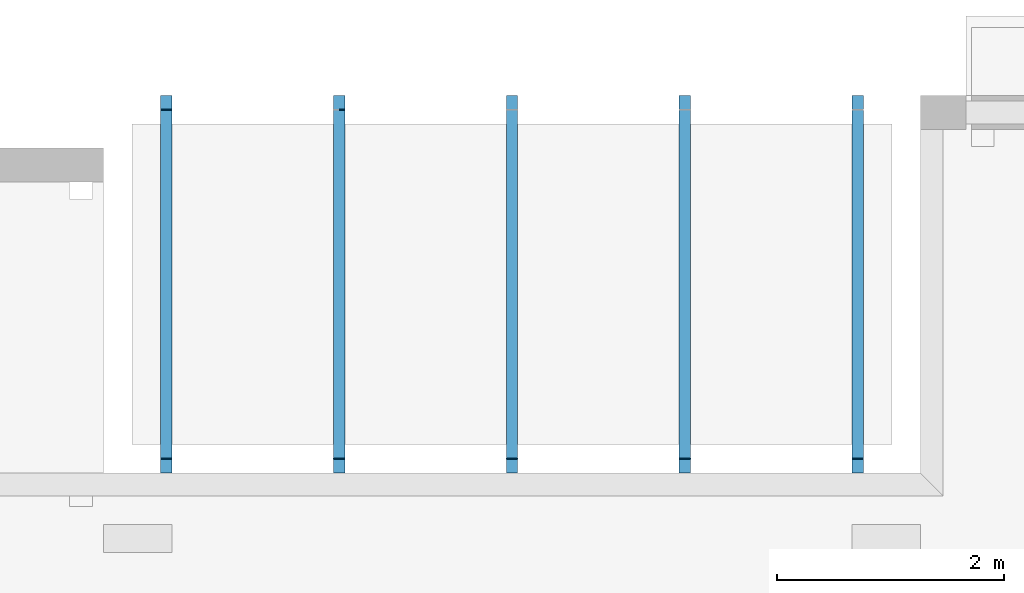
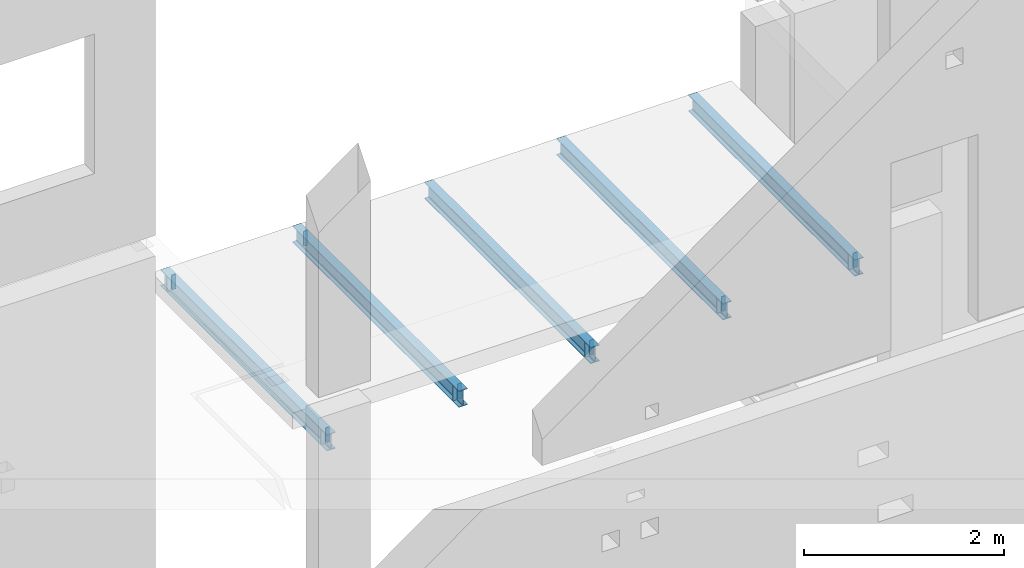
# One storey, part 5 of 7: 18 beams.
"""IFC2X3 building model written with IfcOpenShell, lengths in millimetres."""

from ifc_helpers import new_model, entity, si_unit, converted_unit, derived_unit, money_unit, direction, frame, origin_with_axes, place, context, subcontext, project, spatial, faceted_brep, material, type_object, element, save


model = new_model("IFC2X3")

# Units and contexts
model_context = context("Model", 3, precision=1e-05, world=origin_with_axes(), true_north=direction((0.0, 1.0)))
body_context = subcontext(model_context, "Body", "Model", "MODEL_VIEW", scale=1.0)
ifc_project = project(units=[si_unit("LENGTHUNIT", "METRE", prefix="MILLI"), si_unit("AREAUNIT", "SQUARE_METRE"), si_unit("VOLUMEUNIT", "CUBIC_METRE"), si_unit("ABSORBEDDOSEUNIT", "GRAY"), si_unit("AMOUNTOFSUBSTANCEUNIT", "MOLE"), si_unit("DOSEEQUIVALENTUNIT", "SIEVERT"), si_unit("ELECTRICCAPACITANCEUNIT", "FARAD"), si_unit("ELECTRICCHARGEUNIT", "COULOMB"), si_unit("ELECTRICCONDUCTANCEUNIT", "SIEMENS"), si_unit("ELECTRICCURRENTUNIT", "AMPERE"), si_unit("ELECTRICRESISTANCEUNIT", "OHM"), si_unit("ELECTRICVOLTAGEUNIT", "VOLT"), si_unit("ENERGYUNIT", "JOULE"), si_unit("FORCEUNIT", "NEWTON"), si_unit("FREQUENCYUNIT", "HERTZ"), si_unit("ILLUMINANCEUNIT", "LUX"), si_unit("INDUCTANCEUNIT", "HENRY"), si_unit("LUMINOUSFLUXUNIT", "LUMEN"), si_unit("LUMINOUSINTENSITYUNIT", "CANDELA"), si_unit("MAGNETICFLUXDENSITYUNIT", "TESLA"), si_unit("MAGNETICFLUXUNIT", "WEBER"), si_unit("MASSUNIT", "GRAM"), converted_unit("PLANEANGLEUNIT", "degree", entity("IfcReal", 0.0174532925199433), si_unit("PLANEANGLEUNIT", "RADIAN"), dimensions=[0, 0, 0, 0, 0, 0, 0]), si_unit("POWERUNIT", "WATT"), si_unit("PRESSUREUNIT", "PASCAL"), si_unit("RADIOACTIVITYUNIT", "BECQUEREL"), si_unit("SOLIDANGLEUNIT", "STERADIAN"), si_unit("THERMODYNAMICTEMPERATUREUNIT", "KELVIN"), si_unit("TIMEUNIT", "SECOND"), derived_unit("ACCELERATIONUNIT", [(si_unit("LENGTHUNIT", "METRE", prefix="MILLI"), 1), (si_unit("TIMEUNIT", "SECOND"), -2)]), derived_unit("ANGULARVELOCITYUNIT", [(converted_unit("PLANEANGLEUNIT", "degree", entity("IfcReal", 0.0174532925199433), si_unit("PLANEANGLEUNIT", "RADIAN"), dimensions=[0, 0, 0, 0, 0, 0, 0]), 1), (si_unit("TIMEUNIT", "SECOND"), -1)]), derived_unit("CURVATUREUNIT", [(converted_unit("PLANEANGLEUNIT", "degree", entity("IfcReal", 0.0174532925199433), si_unit("PLANEANGLEUNIT", "RADIAN"), dimensions=[0, 0, 0, 0, 0, 0, 0]), 1), (si_unit("LENGTHUNIT", "METRE", prefix="MILLI"), -1)]), derived_unit("DYNAMICVISCOSITYUNIT", [(si_unit("PRESSUREUNIT", "PASCAL"), 1), (si_unit("TIMEUNIT", "SECOND"), 1)]), derived_unit("HEATFLUXDENSITYUNIT", [(si_unit("POWERUNIT", "WATT"), 1), (si_unit("LENGTHUNIT", "METRE", prefix="MILLI"), -2)]), derived_unit("HEATINGVALUEUNIT", [(si_unit("ENERGYUNIT", "JOULE"), 1), (si_unit("MASSUNIT", "GRAM"), -1)]), derived_unit("INTEGERCOUNTRATEUNIT", [(si_unit("TIMEUNIT", "SECOND"), -1)]), derived_unit("IONCONCENTRATIONUNIT", [(si_unit("MASSUNIT", "GRAM"), 1), (si_unit("VOLUMEUNIT", "CUBIC_METRE"), -1)]), derived_unit("ISOTHERMALMOISTURECAPACITYUNIT", [(si_unit("VOLUMEUNIT", "CUBIC_METRE"), 1), (si_unit("MASSUNIT", "GRAM"), -1)]), derived_unit("KINEMATICVISCOSITYUNIT", [(si_unit("AREAUNIT", "SQUARE_METRE"), 1), (si_unit("TIMEUNIT", "SECOND"), -1)]), derived_unit("LINEARFORCEUNIT", [(si_unit("FORCEUNIT", "NEWTON"), 1), (si_unit("LENGTHUNIT", "METRE", prefix="MILLI"), -1)]), derived_unit("LINEARMOMENTUNIT", [(si_unit("FORCEUNIT", "NEWTON"), 1), (si_unit("LENGTHUNIT", "METRE", prefix="MILLI"), -1)]), derived_unit("LINEARSTIFFNESSUNIT", [(si_unit("FORCEUNIT", "NEWTON"), 1), (si_unit("LENGTHUNIT", "METRE", prefix="MILLI"), -1)]), derived_unit("LINEARVELOCITYUNIT", [(si_unit("LENGTHUNIT", "METRE", prefix="MILLI"), 1), (si_unit("TIMEUNIT", "SECOND"), -1)]), derived_unit("LUMINOUSINTENSITYDISTRIBUTIONUNIT", [(si_unit("LUMINOUSINTENSITYUNIT", "CANDELA"), 1), (si_unit("LUMINOUSFLUXUNIT", "LUMEN"), -1)]), derived_unit("MASSDENSITYUNIT", [(si_unit("MASSUNIT", "GRAM"), 1), (si_unit("VOLUMEUNIT", "CUBIC_METRE"), -1)]), derived_unit("MASSFLOWRATEUNIT", [(si_unit("MASSUNIT", "GRAM"), 1), (si_unit("TIMEUNIT", "SECOND"), -1)]), derived_unit("MASSPERLENGTHUNIT", [(si_unit("MASSUNIT", "GRAM"), 1), (si_unit("LENGTHUNIT", "METRE", prefix="MILLI"), -1)]), derived_unit("MODULUSOFELASTICITYUNIT", [(si_unit("FORCEUNIT", "NEWTON"), 1), (si_unit("AREAUNIT", "SQUARE_METRE"), -1)]), derived_unit("MODULUSOFLINEARSUBGRADEREACTIONUNIT", [(si_unit("FORCEUNIT", "NEWTON"), 1), (si_unit("LENGTHUNIT", "METRE", prefix="MILLI"), -2)]), derived_unit("MODULUSOFROTATIONALSUBGRADEREACTIONUNIT", [(si_unit("FORCEUNIT", "NEWTON"), 1), (si_unit("LENGTHUNIT", "METRE", prefix="MILLI"), 1)]), derived_unit("MODULUSOFSUBGRADEREACTIONUNIT", [(si_unit("FORCEUNIT", "NEWTON"), 1), (si_unit("VOLUMEUNIT", "CUBIC_METRE"), -1)]), derived_unit("MOISTUREDIFFUSIVITYUNIT", [(si_unit("VOLUMEUNIT", "CUBIC_METRE"), 1), (si_unit("TIMEUNIT", "SECOND"), -1)]), derived_unit("MOLECULARWEIGHTUNIT", [(si_unit("MASSUNIT", "GRAM"), 1), (si_unit("AMOUNTOFSUBSTANCEUNIT", "MOLE"), -1)]), derived_unit("PLANARFORCEUNIT", [(si_unit("FORCEUNIT", "NEWTON"), 1), (si_unit("LENGTHUNIT", "METRE", prefix="MILLI"), -2)]), derived_unit("ROTATIONALFREQUENCYUNIT", [(si_unit("TIMEUNIT", "SECOND"), -1)]), derived_unit("ROTATIONALMASSUNIT", [(si_unit("MASSUNIT", "GRAM"), 1), (si_unit("LENGTHUNIT", "METRE", prefix="MILLI"), 2)]), derived_unit("ROTATIONALSTIFFNESSUNIT", [(si_unit("FORCEUNIT", "NEWTON"), 1), (si_unit("LENGTHUNIT", "METRE", prefix="MILLI"), 1), (converted_unit("PLANEANGLEUNIT", "degree", entity("IfcReal", 0.0174532925199433), si_unit("PLANEANGLEUNIT", "RADIAN"), dimensions=[0, 0, 0, 0, 0, 0, 0]), -1)]), derived_unit("SECTIONAREAINTEGRALUNIT", [(si_unit("LENGTHUNIT", "METRE", prefix="MILLI"), 5)]), derived_unit("SECTIONMODULUSUNIT", [(si_unit("LENGTHUNIT", "METRE", prefix="MILLI"), 3)]), derived_unit("SHEARMODULUSUNIT", [(si_unit("FORCEUNIT", "NEWTON"), 1), (si_unit("AREAUNIT", "SQUARE_METRE"), -1)]), derived_unit("SOUNDPOWERUNIT", [(si_unit("ENERGYUNIT", "JOULE"), 1), (si_unit("TIMEUNIT", "SECOND"), -1)]), derived_unit("SPECIFICHEATCAPACITYUNIT", [(si_unit("FORCEUNIT", "NEWTON"), 1), (si_unit("MASSUNIT", "GRAM"), -1), (si_unit("THERMODYNAMICTEMPERATUREUNIT", "KELVIN"), -1)]), derived_unit("TEMPERATUREGRADIENTUNIT", [(si_unit("THERMODYNAMICTEMPERATUREUNIT", "KELVIN"), 1), (si_unit("LENGTHUNIT", "METRE", prefix="MILLI"), -1)]), derived_unit("THERMALADMITTANCEUNIT", [(si_unit("POWERUNIT", "WATT"), 1), (si_unit("AREAUNIT", "SQUARE_METRE"), -1), (si_unit("THERMODYNAMICTEMPERATUREUNIT", "KELVIN"), -1)]), derived_unit("THERMALCONDUCTANCEUNIT", [(si_unit("POWERUNIT", "WATT"), 1), (si_unit("LENGTHUNIT", "METRE", prefix="MILLI"), -1), (si_unit("THERMODYNAMICTEMPERATUREUNIT", "KELVIN"), -1)]), derived_unit("THERMALEXPANSIONCOEFFICIENTUNIT", [(si_unit("THERMODYNAMICTEMPERATUREUNIT", "KELVIN"), -1)]), derived_unit("THERMALRESISTANCEUNIT", [(si_unit("AREAUNIT", "SQUARE_METRE"), 1), (si_unit("POWERUNIT", "WATT"), -1)]), derived_unit("THERMALTRANSMITTANCEUNIT", [(si_unit("POWERUNIT", "WATT"), 1), (si_unit("AREAUNIT", "SQUARE_METRE"), -1), (si_unit("THERMODYNAMICTEMPERATUREUNIT", "KELVIN"), -1)]), derived_unit("TORQUEUNIT", [(si_unit("FORCEUNIT", "NEWTON"), 1), (si_unit("LENGTHUNIT", "METRE", prefix="MILLI"), 1)]), derived_unit("VAPORPERMEABILITYUNIT", [(si_unit("MASSUNIT", "GRAM"), 1), (si_unit("TIMEUNIT", "SECOND"), -1)]), derived_unit("VOLUMETRICFLOWRATEUNIT", [(si_unit("VOLUMEUNIT", "CUBIC_METRE"), 1), (si_unit("TIMEUNIT", "SECOND"), -1)]), derived_unit("WARPINGCONSTANTUNIT", [(si_unit("LENGTHUNIT", "METRE", prefix="MILLI"), 6)]), derived_unit("WARPINGMOMENTUNIT", [(si_unit("FORCEUNIT", "NEWTON"), 1), (si_unit("LENGTHUNIT", "METRE", prefix="MILLI"), 2)]), money_unit("USD")], contexts=[model_context])

# Site, building, storey
site_placement = place(None, origin_with_axes())
site = spatial("IfcSite", under=ifc_project, at=site_placement, CompositionType="ELEMENT")
building_placement = place(site_placement, origin_with_axes())
building = spatial("IfcBuilding", under=site, at=building_placement, Name="1", CompositionType="ELEMENT")
storey_placement = place(building_placement, frame((0.0, 0.0, -4900.0), z_axis=(0.0, 0.0, 1.0), x_axis=(1.0, 0.0, 0.0)))
storey = spatial("IfcBuildingStorey", under=building, at=storey_placement, CompositionType="ELEMENT", Elevation=-4900.0)

# Beams
ifc_material = material()
beam_type = type_object("IfcBeamType", PredefinedType="BEAM")
beam_1_placement = place(storey_placement, frame((0.0, 0.0, 4900.0), z_axis=(0.0, 0.0, 1.0), x_axis=(1.0, 0.0, 0.0)))
element("IfcBeam", 1, at=beam_1_placement, inside=storey, type_object=beam_type, material=ifc_material, context=body_context, shape_type="Brep", body=[
    faceted_brep([(9475.0, 10060.0, -1400.0), (9475.0, 6740.0, -1400.0), (9475.0, 6740.0, -1392.0), (9475.0, 10060.0, -1392.0), (9511.25, 6740.0, -1392.0), (9511.25, 10060.0, -1392.0), (9515.459518, 6740.0, -1391.162675), (9515.459518, 10060.0, -1391.162675), (9519.028175, 6740.0, -1388.778175), (9519.028175, 10060.0, -1388.778175), (9521.412675, 6740.0, -1385.209518), (9521.412675, 10060.0, -1385.209518), (9522.25, 6740.0, -1381.0), (9522.25, 10060.0, -1381.0), (9522.25, 10060.0, -1219.0), (9521.412675, 10060.0, -1214.790482), (9519.028175, 10060.0, -1211.221825), (9515.459518, 10060.0, -1208.837325), (9511.25, 10060.0, -1208.0), (9475.0, 10060.0, -1208.0), (9475.0, 10060.0, -1200.0), (9575.0, 10060.0, -1200.0), (9575.0, 10060.0, -1208.0), (9538.75, 10060.0, -1208.0), (9534.540482, 10060.0, -1208.837325), (9530.971825, 10060.0, -1211.221825), (9528.587325, 10060.0, -1214.790482), (9527.75, 10060.0, -1219.0), (9527.75, 10060.0, -1381.0), (9528.587325, 10060.0, -1385.209518), (9530.971825, 10060.0, -1388.778175), (9534.540482, 10060.0, -1391.162675), (9538.75, 10060.0, -1392.0), (9575.0, 10060.0, -1392.0), (9575.0, 10060.0, -1400.0), (9575.0, 6740.0, -1400.0), (9575.0, 6740.0, -1392.0), (9538.75, 6740.0, -1392.0), (9534.540482, 6740.0, -1391.162675), (9530.971825, 6740.0, -1388.778175), (9528.587325, 6740.0, -1385.209518), (9527.75, 6740.0, -1381.0), (9527.75, 6740.0, -1219.0), (9528.587325, 6740.0, -1214.790482), (9530.971825, 6740.0, -1211.221825), (9534.540482, 6740.0, -1208.837325), (9538.75, 6740.0, -1208.0), (9575.0, 6740.0, -1208.0), (9575.0, 6740.0, -1200.0), (9475.0, 6740.0, -1200.0), (9475.0, 6740.0, -1208.0), (9511.25, 6740.0, -1208.0), (9515.459518, 6740.0, -1208.837325), (9519.028175, 6740.0, -1211.221825), (9521.412675, 6740.0, -1214.790482), (9522.25, 6740.0, -1219.0)], [[[0, 1, 2, 3]], [[3, 2, 4, 5]], [[5, 4, 6, 7]], [[7, 6, 8, 9]], [[9, 8, 10, 11]], [[11, 10, 12, 13]], [[0, 3, 5, 7, 9, 11, 13, 14, 15, 16, 17, 18, 19, 20, 21, 22, 23, 24, 25, 26, 27, 28, 29, 30, 31, 32, 33, 34]], [[35, 36, 37, 38, 39, 40, 41, 42, 43, 44, 45, 46, 47, 48, 49, 50, 51, 52, 53, 54, 55, 12, 10, 8, 6, 4, 2, 1]], [[13, 12, 55, 14]], [[14, 55, 54, 15]], [[15, 54, 53, 16]], [[16, 53, 52, 17]], [[17, 52, 51, 18]], [[18, 51, 50, 19]], [[19, 50, 49, 20]], [[20, 49, 48, 21]], [[21, 48, 47, 22]], [[22, 47, 46, 23]], [[23, 46, 45, 24]], [[24, 45, 44, 25]], [[25, 44, 43, 26]], [[26, 43, 42, 27]], [[27, 42, 41, 28]], [[28, 41, 40, 29]], [[29, 40, 39, 30]], [[30, 39, 38, 31]], [[31, 38, 37, 32]], [[32, 37, 36, 33]], [[33, 36, 35, 34]], [[34, 35, 1, 0]]]),
])
beam_2_placement = place(storey_placement, frame((0.0, 0.0, 4900.0), z_axis=(0.0, 0.0, 1.0), x_axis=(1.0, 0.0, 0.0)))
element("IfcBeam", 2, at=beam_2_placement, inside=storey, type_object=beam_type, material=ifc_material, context=body_context, shape_type="Brep", body=[
    faceted_brep([(9527.0, 6860.0, -1382.0), (9538.0, 6860.0, -1392.0), (9575.0, 6860.0, -1392.0), (9575.0, 6860.0, -1208.0), (9537.0, 6860.0, -1208.0), (9527.0, 6860.0, -1218.0), (9538.0, 6870.0, -1392.0), (9527.0, 6870.0, -1382.0), (9527.0, 6870.0, -1218.0), (9537.0, 6870.0, -1208.0), (9575.0, 6870.0, -1208.0), (9575.0, 6870.0, -1392.0)], [[[0, 1, 2, 3, 4, 5]], [[6, 7, 8, 9, 10, 11]], [[3, 2, 11, 10]], [[6, 11, 2, 1]], [[9, 4, 3, 10]], [[8, 7, 0, 5]], [[7, 6, 1, 0]], [[9, 8, 5, 4]]]),
])
beam_3_placement = place(storey_placement, frame((0.0, 0.0, 4900.0), z_axis=(0.0, 0.0, 1.0), x_axis=(1.0, 0.0, 0.0)))
element("IfcBeam", 3, at=beam_3_placement, inside=storey, type_object=beam_type, material=ifc_material, context=body_context, shape_type="Brep", body=[
    faceted_brep([(9512.0, 6860.0, -1392.0), (9523.0, 6860.0, -1382.0), (9523.0, 6860.0, -1218.0), (9513.0, 6860.0, -1208.0), (9475.0, 6860.0, -1208.0), (9475.0, 6860.0, -1392.0), (9523.0, 6870.0, -1382.0), (9512.0, 6870.0, -1392.0), (9475.0, 6870.0, -1392.0), (9475.0, 6870.0, -1208.0), (9513.0, 6870.0, -1208.0), (9523.0, 6870.0, -1218.0)], [[[0, 1, 2, 3, 4, 5]], [[6, 7, 8, 9, 10, 11]], [[0, 5, 8, 7]], [[3, 10, 9, 4]], [[9, 8, 5, 4]], [[7, 6, 1, 0]], [[6, 11, 2, 1]], [[11, 10, 3, 2]]]),
])
beam_4_placement = place(storey_placement, frame((0.0, 0.0, 4900.0), z_axis=(0.0, 0.0, 1.0), x_axis=(1.0, 0.0, 0.0)))
element("IfcBeam", 4, at=beam_4_placement, inside=storey, type_object=beam_type, material=ifc_material, context=body_context, shape_type="Brep", body=[
    faceted_brep([(9527.0, 9930.0, -1382.0), (9538.0, 9930.0, -1392.0), (9575.0, 9930.0, -1392.0), (9575.0, 9930.0, -1208.0), (9537.0, 9930.0, -1208.0), (9527.0, 9930.0, -1218.0), (9538.0, 9940.0, -1392.0), (9527.0, 9940.0, -1382.0), (9527.0, 9940.0, -1218.0), (9537.0, 9940.0, -1208.0), (9575.0, 9940.0, -1208.0), (9575.0, 9940.0, -1392.0)], [[[0, 1, 2, 3, 4, 5]], [[6, 7, 8, 9, 10, 11]], [[3, 2, 11, 10]], [[6, 11, 2, 1]], [[9, 4, 3, 10]], [[8, 7, 0, 5]], [[7, 6, 1, 0]], [[9, 8, 5, 4]]]),
])
beam_5_placement = place(storey_placement, frame((0.0, 0.0, 4900.0), z_axis=(0.0, 0.0, 1.0), x_axis=(1.0, 0.0, 0.0)))
element("IfcBeam", 5, at=beam_5_placement, inside=storey, type_object=beam_type, material=ifc_material, context=body_context, shape_type="Brep", body=[
    faceted_brep([(9512.0, 9930.0, -1392.0), (9523.0, 9930.0, -1382.0), (9523.0, 9930.0, -1218.0), (9513.0, 9930.0, -1208.0), (9475.0, 9930.0, -1208.0), (9475.0, 9930.0, -1392.0), (9523.0, 9940.0, -1382.0), (9512.0, 9940.0, -1392.0), (9475.0, 9940.0, -1392.0), (9475.0, 9940.0, -1208.0), (9513.0, 9940.0, -1208.0), (9523.0, 9940.0, -1218.0)], [[[0, 1, 2, 3, 4, 5]], [[6, 7, 8, 9, 10, 11]], [[0, 5, 8, 7]], [[3, 10, 9, 4]], [[9, 8, 5, 4]], [[7, 6, 1, 0]], [[6, 11, 2, 1]], [[11, 10, 3, 2]]]),
])
beam_6_placement = place(storey_placement, frame((0.0, 0.0, 4900.0), z_axis=(0.0, 0.0, 1.0), x_axis=(1.0, 0.0, 0.0)))
element("IfcBeam", 6, at=beam_6_placement, inside=storey, type_object=beam_type, material=ifc_material, context=body_context, shape_type="Brep", body=[
    faceted_brep([(10995.0, 10060.0, -1400.0), (10995.0, 6740.0, -1400.0), (10995.0, 6740.0, -1392.0), (10995.0, 10060.0, -1392.0), (11031.25, 6740.0, -1392.0), (11031.25, 10060.0, -1392.0), (11035.459518, 6740.0, -1391.162675), (11035.459518, 10060.0, -1391.162675), (11039.028175, 6740.0, -1388.778175), (11039.028175, 10060.0, -1388.778175), (11041.412675, 6740.0, -1385.209518), (11041.412675, 10060.0, -1385.209518), (11042.25, 6740.0, -1381.0), (11042.25, 10060.0, -1381.0), (11042.25, 10060.0, -1219.0), (11041.412675, 10060.0, -1214.790482), (11039.028175, 10060.0, -1211.221825), (11035.459518, 10060.0, -1208.837325), (11031.25, 10060.0, -1208.0), (10995.0, 10060.0, -1208.0), (10995.0, 10060.0, -1200.0), (11095.0, 10060.0, -1200.0), (11095.0, 10060.0, -1208.0), (11058.75, 10060.0, -1208.0), (11054.540482, 10060.0, -1208.837325), (11050.971825, 10060.0, -1211.221825), (11048.587325, 10060.0, -1214.790482), (11047.75, 10060.0, -1219.0), (11047.75, 10060.0, -1381.0), (11048.587325, 10060.0, -1385.209518), (11050.971825, 10060.0, -1388.778175), (11054.540482, 10060.0, -1391.162675), (11058.75, 10060.0, -1392.0), (11095.0, 10060.0, -1392.0), (11095.0, 10060.0, -1400.0), (11095.0, 6740.0, -1400.0), (11095.0, 6740.0, -1392.0), (11058.75, 6740.0, -1392.0), (11054.540482, 6740.0, -1391.162675), (11050.971825, 6740.0, -1388.778175), (11048.587325, 6740.0, -1385.209518), (11047.75, 6740.0, -1381.0), (11047.75, 6740.0, -1219.0), (11048.587325, 6740.0, -1214.790482), (11050.971825, 6740.0, -1211.221825), (11054.540482, 6740.0, -1208.837325), (11058.75, 6740.0, -1208.0), (11095.0, 6740.0, -1208.0), (11095.0, 6740.0, -1200.0), (10995.0, 6740.0, -1200.0), (10995.0, 6740.0, -1208.0), (11031.25, 6740.0, -1208.0), (11035.459518, 6740.0, -1208.837325), (11039.028175, 6740.0, -1211.221825), (11041.412675, 6740.0, -1214.790482), (11042.25, 6740.0, -1219.0)], [[[0, 1, 2, 3]], [[3, 2, 4, 5]], [[5, 4, 6, 7]], [[7, 6, 8, 9]], [[9, 8, 10, 11]], [[11, 10, 12, 13]], [[0, 3, 5, 7, 9, 11, 13, 14, 15, 16, 17, 18, 19, 20, 21, 22, 23, 24, 25, 26, 27, 28, 29, 30, 31, 32, 33, 34]], [[35, 36, 37, 38, 39, 40, 41, 42, 43, 44, 45, 46, 47, 48, 49, 50, 51, 52, 53, 54, 55, 12, 10, 8, 6, 4, 2, 1]], [[13, 12, 55, 14]], [[14, 55, 54, 15]], [[15, 54, 53, 16]], [[16, 53, 52, 17]], [[17, 52, 51, 18]], [[18, 51, 50, 19]], [[19, 50, 49, 20]], [[20, 49, 48, 21]], [[21, 48, 47, 22]], [[22, 47, 46, 23]], [[23, 46, 45, 24]], [[24, 45, 44, 25]], [[25, 44, 43, 26]], [[26, 43, 42, 27]], [[27, 42, 41, 28]], [[28, 41, 40, 29]], [[29, 40, 39, 30]], [[30, 39, 38, 31]], [[31, 38, 37, 32]], [[32, 37, 36, 33]], [[33, 36, 35, 34]], [[34, 35, 1, 0]]]),
])
beam_7_placement = place(storey_placement, frame((0.0, 0.0, 4900.0), z_axis=(0.0, 0.0, 1.0), x_axis=(1.0, 0.0, 0.0)))
element("IfcBeam", 7, at=beam_7_placement, inside=storey, type_object=beam_type, material=ifc_material, context=body_context, shape_type="Brep", body=[
    faceted_brep([(11047.0, 6860.0, -1382.0), (11058.0, 6860.0, -1392.0), (11095.0, 6860.0, -1392.0), (11095.0, 6860.0, -1208.0), (11057.0, 6860.0, -1208.0), (11047.0, 6860.0, -1218.0), (11058.0, 6870.0, -1392.0), (11047.0, 6870.0, -1382.0), (11047.0, 6870.0, -1218.0), (11057.0, 6870.0, -1208.0), (11095.0, 6870.0, -1208.0), (11095.0, 6870.0, -1392.0)], [[[0, 1, 2, 3, 4, 5]], [[6, 7, 8, 9, 10, 11]], [[3, 2, 11, 10]], [[6, 11, 2, 1]], [[9, 4, 3, 10]], [[8, 7, 0, 5]], [[7, 6, 1, 0]], [[9, 8, 5, 4]]]),
])
beam_8_placement = place(storey_placement, frame((0.0, 0.0, 4900.0), z_axis=(0.0, 0.0, 1.0), x_axis=(1.0, 0.0, 0.0)))
element("IfcBeam", 8, at=beam_8_placement, inside=storey, type_object=beam_type, material=ifc_material, context=body_context, shape_type="Brep", body=[
    faceted_brep([(11032.0, 6860.0, -1392.0), (11043.0, 6860.0, -1382.0), (11043.0, 6860.0, -1218.0), (11033.0, 6860.0, -1208.0), (10995.0, 6860.0, -1208.0), (10995.0, 6860.0, -1392.0), (11043.0, 6870.0, -1382.0), (11032.0, 6870.0, -1392.0), (10995.0, 6870.0, -1392.0), (10995.0, 6870.0, -1208.0), (11033.0, 6870.0, -1208.0), (11043.0, 6870.0, -1218.0)], [[[0, 1, 2, 3, 4, 5]], [[6, 7, 8, 9, 10, 11]], [[0, 5, 8, 7]], [[3, 10, 9, 4]], [[9, 8, 5, 4]], [[7, 6, 1, 0]], [[6, 11, 2, 1]], [[11, 10, 3, 2]]]),
])
beam_9_placement = place(storey_placement, frame((0.0, 0.0, 4900.0), z_axis=(0.0, 0.0, 1.0), x_axis=(1.0, 0.0, 0.0)))
element("IfcBeam", 9, at=beam_9_placement, inside=storey, type_object=beam_type, material=ifc_material, context=body_context, shape_type="Brep", body=[
    faceted_brep([(11047.0, 9930.0, -1382.0), (11058.0, 9930.0, -1392.0), (11095.0, 9930.0, -1392.0), (11095.0, 9930.0, -1208.0), (11057.0, 9930.0, -1208.0), (11047.0, 9930.0, -1218.0), (11058.0, 9940.0, -1392.0), (11047.0, 9940.0, -1382.0), (11047.0, 9940.0, -1218.0), (11057.0, 9940.0, -1208.0), (11095.0, 9940.0, -1208.0), (11095.0, 9940.0, -1392.0)], [[[0, 1, 2, 3, 4, 5]], [[6, 7, 8, 9, 10, 11]], [[3, 2, 11, 10]], [[6, 11, 2, 1]], [[9, 4, 3, 10]], [[8, 7, 0, 5]], [[7, 6, 1, 0]], [[9, 8, 5, 4]]]),
])
beam_10_placement = place(storey_placement, frame((0.0, 0.0, 4900.0), z_axis=(0.0, 0.0, 1.0), x_axis=(1.0, 0.0, 0.0)))
element("IfcBeam", 10, at=beam_10_placement, inside=storey, type_object=beam_type, material=ifc_material, context=body_context, shape_type="Brep", body=[
    faceted_brep([(12515.0, 10060.0, -1400.0), (12515.0, 6740.0, -1400.0), (12515.0, 6740.0, -1392.0), (12515.0, 10060.0, -1392.0), (12551.25, 6740.0, -1392.0), (12551.25, 10060.0, -1392.0), (12555.459518, 6740.0, -1391.162675), (12555.459518, 10060.0, -1391.162675), (12559.028175, 6740.0, -1388.778175), (12559.028175, 10060.0, -1388.778175), (12561.412675, 6740.0, -1385.209518), (12561.412675, 10060.0, -1385.209518), (12562.25, 6740.0, -1381.0), (12562.25, 10060.0, -1381.0), (12562.25, 10060.0, -1219.0), (12561.412675, 10060.0, -1214.790482), (12559.028175, 10060.0, -1211.221825), (12555.459518, 10060.0, -1208.837325), (12551.25, 10060.0, -1208.0), (12515.0, 10060.0, -1208.0), (12515.0, 10060.0, -1200.0), (12615.0, 10060.0, -1200.0), (12615.0, 10060.0, -1208.0), (12578.75, 10060.0, -1208.0), (12574.540482, 10060.0, -1208.837325), (12570.971825, 10060.0, -1211.221825), (12568.587325, 10060.0, -1214.790482), (12567.75, 10060.0, -1219.0), (12567.75, 10060.0, -1381.0), (12568.587325, 10060.0, -1385.209518), (12570.971825, 10060.0, -1388.778175), (12574.540482, 10060.0, -1391.162675), (12578.75, 10060.0, -1392.0), (12615.0, 10060.0, -1392.0), (12615.0, 10060.0, -1400.0), (12615.0, 6740.0, -1400.0), (12615.0, 6740.0, -1392.0), (12578.75, 6740.0, -1392.0), (12574.540482, 6740.0, -1391.162675), (12570.971825, 6740.0, -1388.778175), (12568.587325, 6740.0, -1385.209518), (12567.75, 6740.0, -1381.0), (12567.75, 6740.0, -1219.0), (12568.587325, 6740.0, -1214.790482), (12570.971825, 6740.0, -1211.221825), (12574.540482, 6740.0, -1208.837325), (12578.75, 6740.0, -1208.0), (12615.0, 6740.0, -1208.0), (12615.0, 6740.0, -1200.0), (12515.0, 6740.0, -1200.0), (12515.0, 6740.0, -1208.0), (12551.25, 6740.0, -1208.0), (12555.459518, 6740.0, -1208.837325), (12559.028175, 6740.0, -1211.221825), (12561.412675, 6740.0, -1214.790482), (12562.25, 6740.0, -1219.0)], [[[0, 1, 2, 3]], [[3, 2, 4, 5]], [[5, 4, 6, 7]], [[7, 6, 8, 9]], [[9, 8, 10, 11]], [[11, 10, 12, 13]], [[0, 3, 5, 7, 9, 11, 13, 14, 15, 16, 17, 18, 19, 20, 21, 22, 23, 24, 25, 26, 27, 28, 29, 30, 31, 32, 33, 34]], [[35, 36, 37, 38, 39, 40, 41, 42, 43, 44, 45, 46, 47, 48, 49, 50, 51, 52, 53, 54, 55, 12, 10, 8, 6, 4, 2, 1]], [[13, 12, 55, 14]], [[14, 55, 54, 15]], [[15, 54, 53, 16]], [[16, 53, 52, 17]], [[17, 52, 51, 18]], [[18, 51, 50, 19]], [[19, 50, 49, 20]], [[20, 49, 48, 21]], [[21, 48, 47, 22]], [[22, 47, 46, 23]], [[23, 46, 45, 24]], [[24, 45, 44, 25]], [[25, 44, 43, 26]], [[26, 43, 42, 27]], [[27, 42, 41, 28]], [[28, 41, 40, 29]], [[29, 40, 39, 30]], [[30, 39, 38, 31]], [[31, 38, 37, 32]], [[32, 37, 36, 33]], [[33, 36, 35, 34]], [[34, 35, 1, 0]]]),
])
beam_11_placement = place(storey_placement, frame((0.0, 0.0, 4900.0), z_axis=(0.0, 0.0, 1.0), x_axis=(1.0, 0.0, 0.0)))
element("IfcBeam", 11, at=beam_11_placement, inside=storey, type_object=beam_type, material=ifc_material, context=body_context, shape_type="Brep", body=[
    faceted_brep([(12567.0, 6860.0, -1382.0), (12578.0, 6860.0, -1392.0), (12615.0, 6860.0, -1392.0), (12615.0, 6860.0, -1208.0), (12577.0, 6860.0, -1208.0), (12567.0, 6860.0, -1218.0), (12578.0, 6870.0, -1392.0), (12567.0, 6870.0, -1382.0), (12567.0, 6870.0, -1218.0), (12577.0, 6870.0, -1208.0), (12615.0, 6870.0, -1208.0), (12615.0, 6870.0, -1392.0)], [[[0, 1, 2, 3, 4, 5]], [[6, 7, 8, 9, 10, 11]], [[3, 2, 11, 10]], [[6, 11, 2, 1]], [[9, 4, 3, 10]], [[8, 7, 0, 5]], [[7, 6, 1, 0]], [[9, 8, 5, 4]]]),
])
beam_12_placement = place(storey_placement, frame((0.0, 0.0, 4900.0), z_axis=(0.0, 0.0, 1.0), x_axis=(1.0, 0.0, 0.0)))
element("IfcBeam", 12, at=beam_12_placement, inside=storey, type_object=beam_type, material=ifc_material, context=body_context, shape_type="Brep", body=[
    faceted_brep([(12552.0, 6860.0, -1392.0), (12563.0, 6860.0, -1382.0), (12563.0, 6860.0, -1218.0), (12553.0, 6860.0, -1208.0), (12515.0, 6860.0, -1208.0), (12515.0, 6860.0, -1392.0), (12563.0, 6870.0, -1382.0), (12552.0, 6870.0, -1392.0), (12515.0, 6870.0, -1392.0), (12515.0, 6870.0, -1208.0), (12553.0, 6870.0, -1208.0), (12563.0, 6870.0, -1218.0)], [[[0, 1, 2, 3, 4, 5]], [[6, 7, 8, 9, 10, 11]], [[0, 5, 8, 7]], [[3, 10, 9, 4]], [[9, 8, 5, 4]], [[7, 6, 1, 0]], [[6, 11, 2, 1]], [[11, 10, 3, 2]]]),
])
beam_13_placement = place(storey_placement, frame((0.0, 0.0, 4900.0), z_axis=(0.0, 0.0, 1.0), x_axis=(1.0, 0.0, 0.0)))
element("IfcBeam", 13, at=beam_13_placement, inside=storey, type_object=beam_type, material=ifc_material, context=body_context, shape_type="Brep", body=[
    faceted_brep([(14035.0, 10060.0, -1400.0), (14035.0, 6740.0, -1400.0), (14035.0, 6740.0, -1392.0), (14035.0, 10060.0, -1392.0), (14071.25, 6740.0, -1392.0), (14071.25, 10060.0, -1392.0), (14075.459518, 6740.0, -1391.162675), (14075.459518, 10060.0, -1391.162675), (14079.028175, 6740.0, -1388.778175), (14079.028175, 10060.0, -1388.778175), (14081.412675, 6740.0, -1385.209518), (14081.412675, 10060.0, -1385.209518), (14082.25, 6740.0, -1381.0), (14082.25, 10060.0, -1381.0), (14082.25, 10060.0, -1219.0), (14081.412675, 10060.0, -1214.790482), (14079.028175, 10060.0, -1211.221825), (14075.459518, 10060.0, -1208.837325), (14071.25, 10060.0, -1208.0), (14035.0, 10060.0, -1208.0), (14035.0, 10060.0, -1200.0), (14135.0, 10060.0, -1200.0), (14135.0, 10060.0, -1208.0), (14098.75, 10060.0, -1208.0), (14094.540482, 10060.0, -1208.837325), (14090.971825, 10060.0, -1211.221825), (14088.587325, 10060.0, -1214.790482), (14087.75, 10060.0, -1219.0), (14087.75, 10060.0, -1381.0), (14088.587325, 10060.0, -1385.209518), (14090.971825, 10060.0, -1388.778175), (14094.540482, 10060.0, -1391.162675), (14098.75, 10060.0, -1392.0), (14135.0, 10060.0, -1392.0), (14135.0, 10060.0, -1400.0), (14135.0, 6740.0, -1400.0), (14135.0, 6740.0, -1392.0), (14098.75, 6740.0, -1392.0), (14094.540482, 6740.0, -1391.162675), (14090.971825, 6740.0, -1388.778175), (14088.587325, 6740.0, -1385.209518), (14087.75, 6740.0, -1381.0), (14087.75, 6740.0, -1219.0), (14088.587325, 6740.0, -1214.790482), (14090.971825, 6740.0, -1211.221825), (14094.540482, 6740.0, -1208.837325), (14098.75, 6740.0, -1208.0), (14135.0, 6740.0, -1208.0), (14135.0, 6740.0, -1200.0), (14035.0, 6740.0, -1200.0), (14035.0, 6740.0, -1208.0), (14071.25, 6740.0, -1208.0), (14075.459518, 6740.0, -1208.837325), (14079.028175, 6740.0, -1211.221825), (14081.412675, 6740.0, -1214.790482), (14082.25, 6740.0, -1219.0)], [[[0, 1, 2, 3]], [[3, 2, 4, 5]], [[5, 4, 6, 7]], [[7, 6, 8, 9]], [[9, 8, 10, 11]], [[11, 10, 12, 13]], [[0, 3, 5, 7, 9, 11, 13, 14, 15, 16, 17, 18, 19, 20, 21, 22, 23, 24, 25, 26, 27, 28, 29, 30, 31, 32, 33, 34]], [[35, 36, 37, 38, 39, 40, 41, 42, 43, 44, 45, 46, 47, 48, 49, 50, 51, 52, 53, 54, 55, 12, 10, 8, 6, 4, 2, 1]], [[13, 12, 55, 14]], [[14, 55, 54, 15]], [[15, 54, 53, 16]], [[16, 53, 52, 17]], [[17, 52, 51, 18]], [[18, 51, 50, 19]], [[19, 50, 49, 20]], [[20, 49, 48, 21]], [[21, 48, 47, 22]], [[22, 47, 46, 23]], [[23, 46, 45, 24]], [[24, 45, 44, 25]], [[25, 44, 43, 26]], [[26, 43, 42, 27]], [[27, 42, 41, 28]], [[28, 41, 40, 29]], [[29, 40, 39, 30]], [[30, 39, 38, 31]], [[31, 38, 37, 32]], [[32, 37, 36, 33]], [[33, 36, 35, 34]], [[34, 35, 1, 0]]]),
])
beam_14_placement = place(storey_placement, frame((0.0, 0.0, 4900.0), z_axis=(0.0, 0.0, 1.0), x_axis=(1.0, 0.0, 0.0)))
element("IfcBeam", 14, at=beam_14_placement, inside=storey, type_object=beam_type, material=ifc_material, context=body_context, shape_type="Brep", body=[
    faceted_brep([(14087.0, 6860.0, -1382.0), (14098.0, 6860.0, -1392.0), (14135.0, 6860.0, -1392.0), (14135.0, 6860.0, -1208.0), (14097.0, 6860.0, -1208.0), (14087.0, 6860.0, -1218.0), (14098.0, 6870.0, -1392.0), (14087.0, 6870.0, -1382.0), (14087.0, 6870.0, -1218.0), (14097.0, 6870.0, -1208.0), (14135.0, 6870.0, -1208.0), (14135.0, 6870.0, -1392.0)], [[[0, 1, 2, 3, 4, 5]], [[6, 7, 8, 9, 10, 11]], [[3, 2, 11, 10]], [[6, 11, 2, 1]], [[9, 4, 3, 10]], [[8, 7, 0, 5]], [[7, 6, 1, 0]], [[9, 8, 5, 4]]]),
])
beam_15_placement = place(storey_placement, frame((0.0, 0.0, 4900.0), z_axis=(0.0, 0.0, 1.0), x_axis=(1.0, 0.0, 0.0)))
element("IfcBeam", 15, at=beam_15_placement, inside=storey, type_object=beam_type, material=ifc_material, context=body_context, shape_type="Brep", body=[
    faceted_brep([(14072.0, 6860.0, -1392.0), (14083.0, 6860.0, -1382.0), (14083.0, 6860.0, -1218.0), (14073.0, 6860.0, -1208.0), (14035.0, 6860.0, -1208.0), (14035.0, 6860.0, -1392.0), (14083.0, 6870.0, -1382.0), (14072.0, 6870.0, -1392.0), (14035.0, 6870.0, -1392.0), (14035.0, 6870.0, -1208.0), (14073.0, 6870.0, -1208.0), (14083.0, 6870.0, -1218.0)], [[[0, 1, 2, 3, 4, 5]], [[6, 7, 8, 9, 10, 11]], [[0, 5, 8, 7]], [[3, 10, 9, 4]], [[9, 8, 5, 4]], [[7, 6, 1, 0]], [[6, 11, 2, 1]], [[11, 10, 3, 2]]]),
])
beam_16_placement = place(storey_placement, frame((0.0, 0.0, 4900.0), z_axis=(0.0, 0.0, 1.0), x_axis=(1.0, 0.0, 0.0)))
element("IfcBeam", 16, at=beam_16_placement, inside=storey, type_object=beam_type, material=ifc_material, context=body_context, shape_type="Brep", body=[
    faceted_brep([(15555.0, 10060.0, -1400.0), (15555.0, 6740.0, -1400.0), (15555.0, 6740.0, -1392.0), (15555.0, 10060.0, -1392.0), (15591.25, 6740.0, -1392.0), (15591.25, 10060.0, -1392.0), (15595.459518, 6740.0, -1391.162675), (15595.459518, 10060.0, -1391.162675), (15599.028175, 6740.0, -1388.778175), (15599.028175, 10060.0, -1388.778175), (15601.412675, 6740.0, -1385.209518), (15601.412675, 10060.0, -1385.209518), (15602.25, 6740.0, -1381.0), (15602.25, 10060.0, -1381.0), (15602.25, 10060.0, -1219.0), (15601.412675, 10060.0, -1214.790482), (15599.028175, 10060.0, -1211.221825), (15595.459518, 10060.0, -1208.837325), (15591.25, 10060.0, -1208.0), (15555.0, 10060.0, -1208.0), (15555.0, 10060.0, -1200.0), (15655.0, 10060.0, -1200.0), (15655.0, 10060.0, -1208.0), (15618.75, 10060.0, -1208.0), (15614.540482, 10060.0, -1208.837325), (15610.971825, 10060.0, -1211.221825), (15608.587325, 10060.0, -1214.790482), (15607.75, 10060.0, -1219.0), (15607.75, 10060.0, -1381.0), (15608.587325, 10060.0, -1385.209518), (15610.971825, 10060.0, -1388.778175), (15614.540482, 10060.0, -1391.162675), (15618.75, 10060.0, -1392.0), (15655.0, 10060.0, -1392.0), (15655.0, 10060.0, -1400.0), (15655.0, 6740.0, -1400.0), (15655.0, 6740.0, -1392.0), (15618.75, 6740.0, -1392.0), (15614.540482, 6740.0, -1391.162675), (15610.971825, 6740.0, -1388.778175), (15608.587325, 6740.0, -1385.209518), (15607.75, 6740.0, -1381.0), (15607.75, 6740.0, -1219.0), (15608.587325, 6740.0, -1214.790482), (15610.971825, 6740.0, -1211.221825), (15614.540482, 6740.0, -1208.837325), (15618.75, 6740.0, -1208.0), (15655.0, 6740.0, -1208.0), (15655.0, 6740.0, -1200.0), (15555.0, 6740.0, -1200.0), (15555.0, 6740.0, -1208.0), (15591.25, 6740.0, -1208.0), (15595.459518, 6740.0, -1208.837325), (15599.028175, 6740.0, -1211.221825), (15601.412675, 6740.0, -1214.790482), (15602.25, 6740.0, -1219.0)], [[[0, 1, 2, 3]], [[3, 2, 4, 5]], [[5, 4, 6, 7]], [[7, 6, 8, 9]], [[9, 8, 10, 11]], [[11, 10, 12, 13]], [[0, 3, 5, 7, 9, 11, 13, 14, 15, 16, 17, 18, 19, 20, 21, 22, 23, 24, 25, 26, 27, 28, 29, 30, 31, 32, 33, 34]], [[35, 36, 37, 38, 39, 40, 41, 42, 43, 44, 45, 46, 47, 48, 49, 50, 51, 52, 53, 54, 55, 12, 10, 8, 6, 4, 2, 1]], [[13, 12, 55, 14]], [[14, 55, 54, 15]], [[15, 54, 53, 16]], [[16, 53, 52, 17]], [[17, 52, 51, 18]], [[18, 51, 50, 19]], [[19, 50, 49, 20]], [[20, 49, 48, 21]], [[21, 48, 47, 22]], [[22, 47, 46, 23]], [[23, 46, 45, 24]], [[24, 45, 44, 25]], [[25, 44, 43, 26]], [[26, 43, 42, 27]], [[27, 42, 41, 28]], [[28, 41, 40, 29]], [[29, 40, 39, 30]], [[30, 39, 38, 31]], [[31, 38, 37, 32]], [[32, 37, 36, 33]], [[33, 36, 35, 34]], [[34, 35, 1, 0]]]),
])
beam_17_placement = place(storey_placement, frame((0.0, 0.0, 4900.0), z_axis=(0.0, 0.0, 1.0), x_axis=(1.0, 0.0, 0.0)))
element("IfcBeam", 17, at=beam_17_placement, inside=storey, type_object=beam_type, material=ifc_material, context=body_context, shape_type="Brep", body=[
    faceted_brep([(15607.0, 6860.0, -1382.0), (15618.0, 6860.0, -1392.0), (15655.0, 6860.0, -1392.0), (15655.0, 6860.0, -1208.0), (15617.0, 6860.0, -1208.0), (15607.0, 6860.0, -1218.0), (15618.0, 6870.0, -1392.0), (15607.0, 6870.0, -1382.0), (15607.0, 6870.0, -1218.0), (15617.0, 6870.0, -1208.0), (15655.0, 6870.0, -1208.0), (15655.0, 6870.0, -1392.0)], [[[0, 1, 2, 3, 4, 5]], [[6, 7, 8, 9, 10, 11]], [[3, 2, 11, 10]], [[6, 11, 2, 1]], [[9, 4, 3, 10]], [[8, 7, 0, 5]], [[7, 6, 1, 0]], [[9, 8, 5, 4]]]),
])
beam_18_placement = place(storey_placement, frame((0.0, 0.0, 4900.0), z_axis=(0.0, 0.0, 1.0), x_axis=(1.0, 0.0, 0.0)))
element("IfcBeam", 18, at=beam_18_placement, inside=storey, type_object=beam_type, material=ifc_material, context=body_context, shape_type="Brep", body=[
    faceted_brep([(15592.0, 6860.0, -1392.0), (15603.0, 6860.0, -1382.0), (15603.0, 6860.0, -1218.0), (15593.0, 6860.0, -1208.0), (15555.0, 6860.0, -1208.0), (15555.0, 6860.0, -1392.0), (15603.0, 6870.0, -1382.0), (15592.0, 6870.0, -1392.0), (15555.0, 6870.0, -1392.0), (15555.0, 6870.0, -1208.0), (15593.0, 6870.0, -1208.0), (15603.0, 6870.0, -1218.0)], [[[0, 1, 2, 3, 4, 5]], [[6, 7, 8, 9, 10, 11]], [[0, 5, 8, 7]], [[3, 10, 9, 4]], [[9, 8, 5, 4]], [[7, 6, 1, 0]], [[6, 11, 2, 1]], [[11, 10, 3, 2]]]),
])

save(model, "model.ifc")
